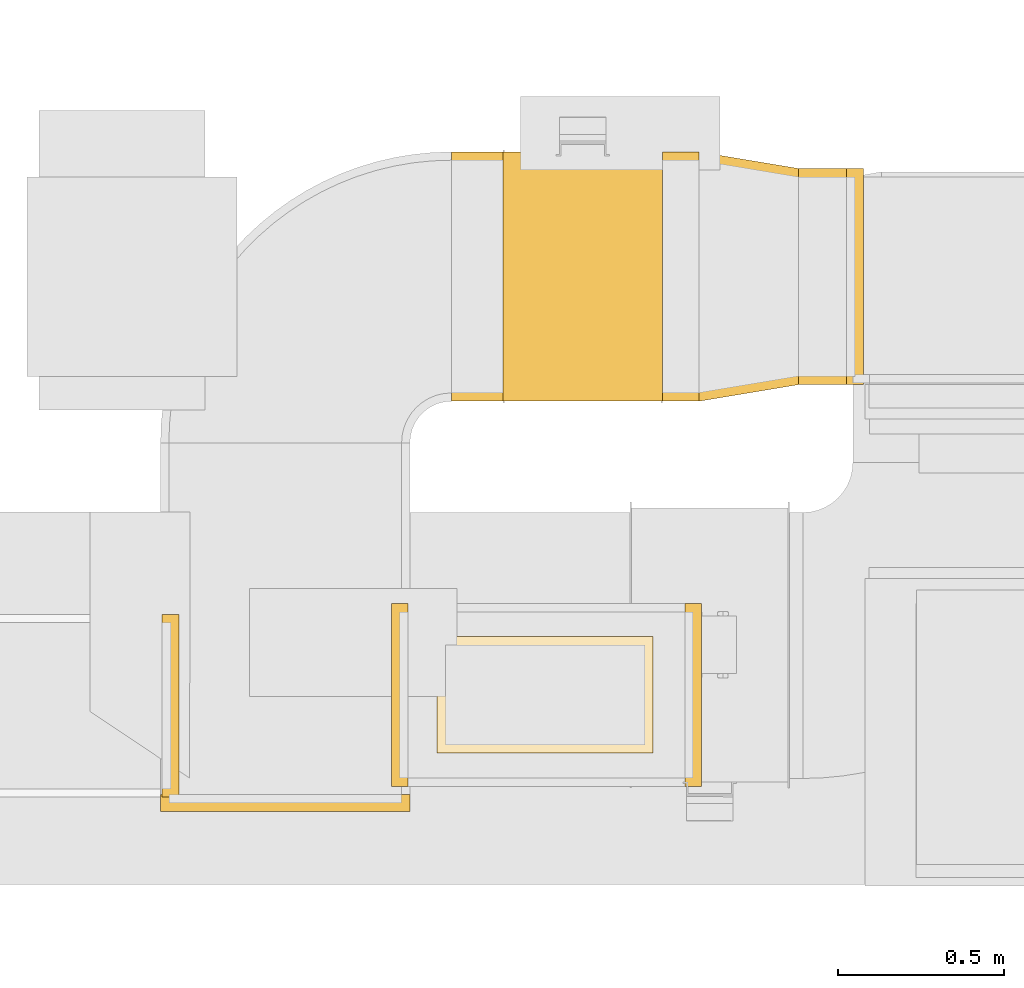
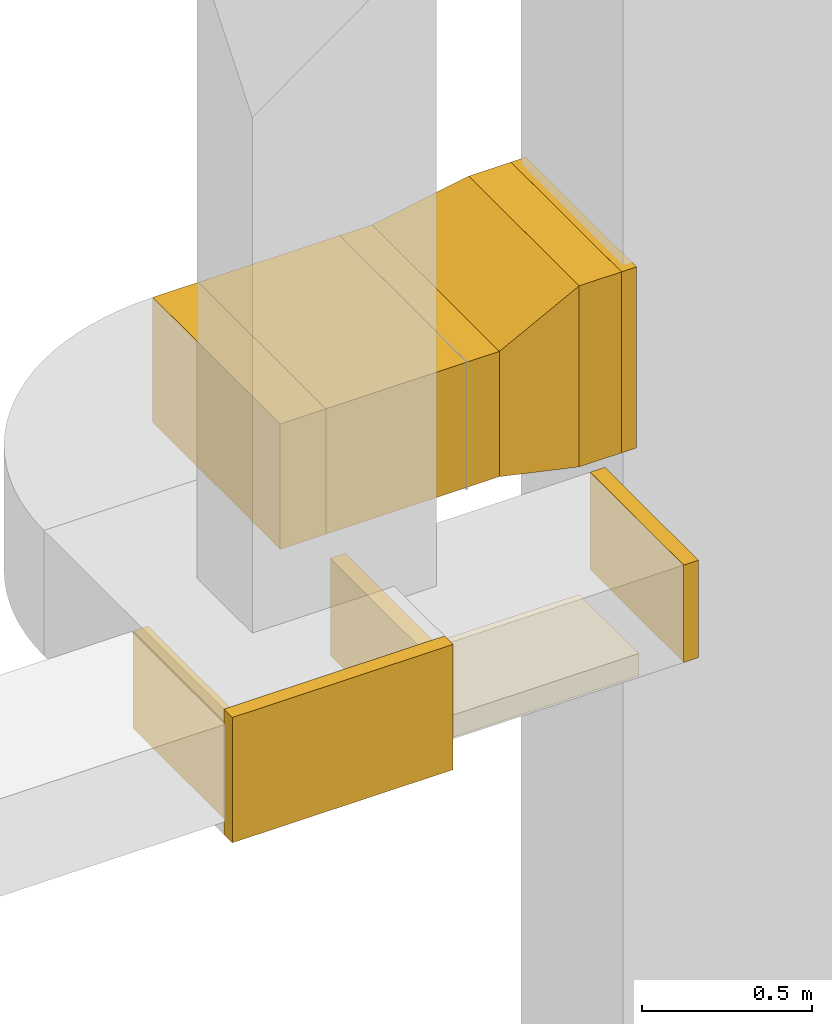
# One storey, part 4 of 25: 11 coverings.
"""IFC2X3 building model written with IfcOpenShell, lengths in millimetres."""

from ifc_helpers import new_model, entity, si_unit, converted_unit, derived_unit, direction, frame, origin, origin_2d_with_axis, place, context, subcontext, project, spatial, rectangle, extrude, faceted_brep, element, save


model = new_model("IFC2X3")

# Units and contexts
model_context = context("Model", 3, precision=0.01, world=origin(), true_north=direction((6.12303176911189e-17, 1.0)))
body_context = subcontext(model_context, "Body", "Model", "MODEL_VIEW")
ifc_project = project(units=[si_unit("LENGTHUNIT", "METRE", prefix="MILLI"), si_unit("AREAUNIT", "SQUARE_METRE"), si_unit("VOLUMEUNIT", "CUBIC_METRE"), converted_unit("PLANEANGLEUNIT", "DEGREE", entity("IfcRatioMeasure", 0.0174532925199433), si_unit("PLANEANGLEUNIT", "RADIAN"), dimensions=[0, 0, 0, 0, 0, 0, 0]), si_unit("MASSUNIT", "GRAM", prefix="KILO"), derived_unit("MASSDENSITYUNIT", [(si_unit("MASSUNIT", "GRAM", prefix="KILO"), 1), (si_unit("LENGTHUNIT", "METRE"), -3)]), derived_unit("MOMENTOFINERTIAUNIT", [(si_unit("LENGTHUNIT", "METRE"), 4)]), si_unit("TIMEUNIT", "SECOND"), si_unit("FREQUENCYUNIT", "HERTZ"), si_unit("THERMODYNAMICTEMPERATUREUNIT", "DEGREE_CELSIUS"), derived_unit("THERMALTRANSMITTANCEUNIT", [(si_unit("MASSUNIT", "GRAM", prefix="KILO"), 1), (si_unit("THERMODYNAMICTEMPERATUREUNIT", "KELVIN"), -1), (si_unit("TIMEUNIT", "SECOND"), -3)]), derived_unit("VOLUMETRICFLOWRATEUNIT", [(si_unit("LENGTHUNIT", "METRE"), 3), (si_unit("TIMEUNIT", "SECOND"), -1)]), derived_unit("MASSFLOWRATEUNIT", [(si_unit("MASSUNIT", "GRAM", prefix="KILO"), 1), (si_unit("TIMEUNIT", "SECOND"), -1)]), derived_unit("ROTATIONALFREQUENCYUNIT", [(si_unit("TIMEUNIT", "SECOND"), -1)]), si_unit("ELECTRICCURRENTUNIT", "AMPERE"), si_unit("ELECTRICVOLTAGEUNIT", "VOLT"), si_unit("POWERUNIT", "WATT"), si_unit("FORCEUNIT", "NEWTON", prefix="KILO"), si_unit("ILLUMINANCEUNIT", "LUX"), si_unit("LUMINOUSFLUXUNIT", "LUMEN"), si_unit("LUMINOUSINTENSITYUNIT", "CANDELA"), derived_unit("USERDEFINED", [(si_unit("MASSUNIT", "GRAM", prefix="KILO"), -1), (si_unit("LENGTHUNIT", "METRE"), -2), (si_unit("TIMEUNIT", "SECOND"), 3), (si_unit("LUMINOUSFLUXUNIT", "LUMEN"), 1)]), derived_unit("LINEARVELOCITYUNIT", [(si_unit("LENGTHUNIT", "METRE"), 1), (si_unit("TIMEUNIT", "SECOND"), -1)]), si_unit("PRESSUREUNIT", "PASCAL"), derived_unit("USERDEFINED", [(si_unit("LENGTHUNIT", "METRE"), -2), (si_unit("MASSUNIT", "GRAM", prefix="KILO"), 1), (si_unit("TIMEUNIT", "SECOND"), -2)]), derived_unit("LINEARFORCEUNIT", [(si_unit("MASSUNIT", "GRAM", prefix="KILO"), 1), (si_unit("LENGTHUNIT", "METRE"), 1), (si_unit("TIMEUNIT", "SECOND"), -2), (si_unit("LENGTHUNIT", "METRE"), -1)]), derived_unit("PLANARFORCEUNIT", [(si_unit("MASSUNIT", "GRAM", prefix="KILO"), 1), (si_unit("LENGTHUNIT", "METRE"), 1), (si_unit("TIMEUNIT", "SECOND"), -2), (si_unit("LENGTHUNIT", "METRE"), -2)])], contexts=[model_context])

# Site, building, storey
site_placement = place(None, origin())
site = spatial("IfcSite", under=ifc_project, at=site_placement, CompositionType="ELEMENT")
building_placement = place(site_placement, origin())
building = spatial("IfcBuilding", under=site, at=building_placement, CompositionType="ELEMENT")
storey_placement = place(building_placement, origin())
storey = spatial("IfcBuildingStorey", under=building, at=storey_placement, CompositionType="ELEMENT", Elevation=0.0)

# Coverings
covering_1_placement = place(storey_placement, frame((61964.28, 9275.08, 2475.0)))
element("IfcCovering", 1, at=covering_1_placement, inside=storey, PredefinedType="INSULATION", context=body_context, shape_type="SweptSolid", body=[
    extrude(rectangle(XDim=49.9999999999948, YDim=550.0, at=origin_2d_with_axis()), frame((25.0, 275.0, 0.0), z_axis=(0.0, 0.0, 1.0), x_axis=(-1.0, 4.54891434412777e-06, 0.0)), (0.0, 0.0, 1.0), 349.999999999999),
])
covering_2_placement = place(storey_placement, frame((61081.4, 9275.08, 2475.0)))
element("IfcCovering", 2, at=covering_2_placement, inside=storey, PredefinedType="INSULATION", context=body_context, shape_type="SweptSolid", body=[
    extrude(rectangle(XDim=51.0960000000016, YDim=550.000000000001, at=origin_2d_with_axis()), frame((25.55, 275.0, 0.0), z_axis=(0.0, 0.0, 1.0), x_axis=(-1.0, 0.0, 0.0)), (0.0, 0.0, 1.0), 350.000000000001),
])
covering_3_placement = place(storey_placement, frame((60392.49, 9242.34, 2475.0)))
element("IfcCovering", 3, at=covering_3_placement, inside=storey, PredefinedType="INSULATION", context=body_context, shape_type="SweptSolid", body=[
    extrude(rectangle(XDim=550.000000000001, YDim=51.1213371379499, at=origin_2d_with_axis()), frame((25.56, 275.0, 0.0), z_axis=(0.0, 0.0, 1.0), x_axis=(0.0, -1.0, 0.0)), (0.0, 0.0, 1.0), 349.999999999999),
])
covering_4_placement = place(storey_placement, frame((62307.09, 10483.51, 2325.0)))
element("IfcCovering", 4, at=covering_4_placement, inside=storey, PredefinedType="INSULATION", context=body_context, shape_type="SweptSolid", body=[
    extrude(rectangle(XDim=143.50000000008, YDim=650.0, at=origin_2d_with_axis()), frame((71.75, 325.0, 0.0), z_axis=(0.0, 0.0, 1.0), x_axis=(-1.0, 0.0, 0.0)), (0.0, 0.0, 1.0), 650.0),
])
covering_5_placement = place(storey_placement, frame((61417.47, 10433.51, 2425.0)))
element("IfcCovering", 5, at=covering_5_placement, inside=storey, PredefinedType="INSULATION", context=body_context, shape_type="SweptSolid", body=[
    extrude(rectangle(XDim=480.000000000008, YDim=750.000000000001, at=origin_2d_with_axis()), frame((240.03, 375.02, 0.0), z_axis=(0.0, 0.0, 1.0), x_axis=(0.999999997250103, 7.41605989871262e-05, 0.0)), (0.0, 0.0, 1.0), 450.0),
])
covering_6_placement = place(storey_placement, frame((60387.5, 9200.09, 2425.0)))
element("IfcCovering", 6, at=covering_6_placement, inside=storey, PredefinedType="INSULATION", context=body_context, shape_type="SweptSolid", body=[
    extrude(rectangle(XDim=50.0000000000016, YDim=750.000000000003, at=origin_2d_with_axis()), frame((375.0, 25.0, 0.0), z_axis=(0.0, 0.0, 1.0), x_axis=(0.0, 1.0, 0.0)), (0.0, 0.0, 1.0), 450.0),
])
covering_7_placement = place(storey_placement, frame((62450.59, 10483.51, 2325.0)))
element("IfcCovering", 7, at=covering_7_placement, inside=storey, PredefinedType="INSULATION", context=body_context, shape_type="SweptSolid", body=[
    extrude(rectangle(XDim=650.0, YDim=51.0960000000016, at=origin_2d_with_axis()), frame((25.55, 325.0, 0.0), z_axis=(0.0, 0.0, 1.0), x_axis=(0.0, -1.0, 0.0)), (0.0, 0.0, 1.0), 650.0),
])
covering_8_placement = place(storey_placement, frame((61897.5, 10433.55, 2425.0)))
element("IfcCovering", 8, at=covering_8_placement, inside=storey, PredefinedType="INSULATION", context=body_context, shape_type="SweptSolid", body=[
    extrude(rectangle(XDim=109.586325142914, YDim=749.999999999998, at=origin_2d_with_axis()), frame((54.79, 375.0, 0.0)), (0.0, 0.0, 1.0), 450.0),
])
covering_9_placement = place(storey_placement, frame((61262.47, 10433.5, 2425.0)))
element("IfcCovering", 9, at=covering_9_placement, inside=storey, PredefinedType="INSULATION", context=body_context, shape_type="SweptSolid", body=[
    extrude(rectangle(XDim=154.999999573749, YDim=750.000000000001, at=origin_2d_with_axis()), frame((77.53, 375.01, 0.0), z_axis=(0.0, 0.0, 1.0), x_axis=(0.999999997250103, 7.41605989985116e-05, 0.0)), (0.0, 0.0, 1.0), 450.0),
])
covering_10_placement = place(storey_placement, frame((61219.35, 9375.08, 2400.0)))
element("IfcCovering", 10, at=covering_10_placement, inside=storey, PredefinedType="INSULATION", context=body_context, shape_type="SweptSolid", body=[
    extrude(rectangle(XDim=650.000000000008, YDim=350.000000000001, at=origin_2d_with_axis()), frame((325.0, 175.0, 0.0), z_axis=(0.0, 0.0, 1.0), x_axis=(-1.0, 0.0, 0.0)), (0.0, 0.0, 1.0), 79.999999999987),
])
covering_11_placement = place(storey_placement, frame((62007.09, 10433.55, 2325.0)))
element("IfcCovering", 11, at=covering_11_placement, inside=storey, PredefinedType="INSULATION", context=body_context, shape_type="Brep", body=[
    faceted_brep([(300.0, 49.96, 650.0), (300.0, 49.96, 0.0), (300.0, 699.96, 0.0), (300.0, 699.96, 650.0), (0.0, 0.0, 550.0), (0.0, 750.0, 550.0), (0.0, 750.0, 100.0), (0.0, 0.0, 100.0)], [[[0, 1, 2, 3]], [[4, 5, 6, 7]], [[4, 7, 1, 0]], [[7, 6, 2, 1]], [[6, 5, 3, 2]], [[5, 4, 0, 3]]]),
])

save(model, "model.ifc")
